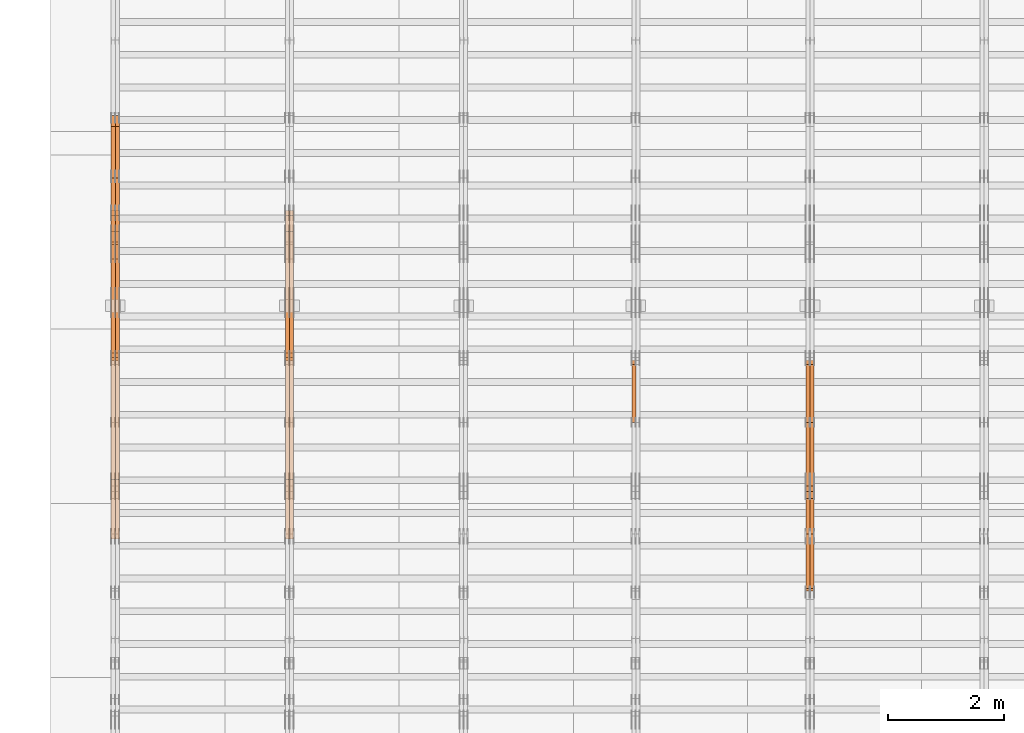
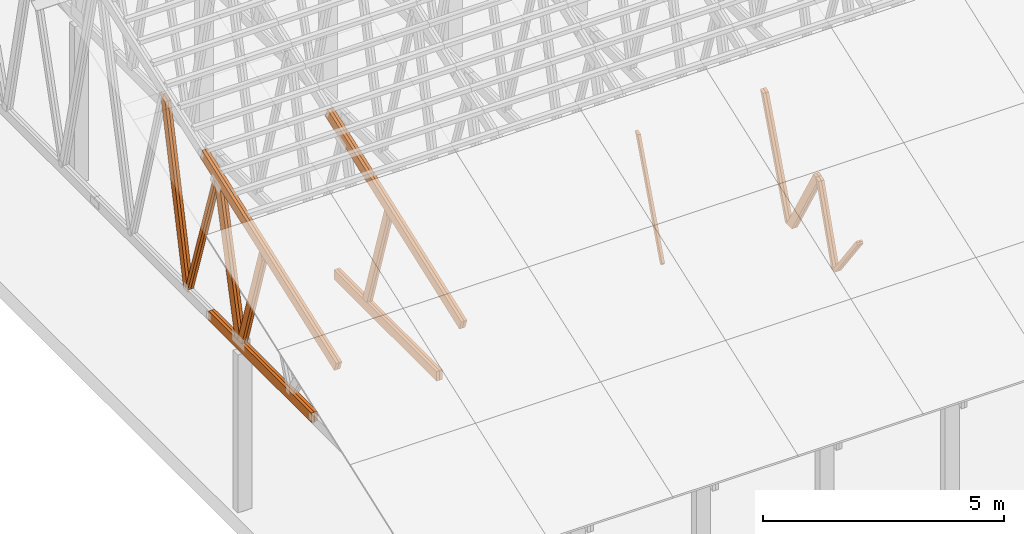
# One storey, part 15 of 189: 27 proxies.
"""IFC2X3 building model written with IfcOpenShell, lengths in millimetres."""

from ifc_helpers import new_model, entity, si_unit, converted_unit, derived_unit, direction, frame, origin, origin_2d_with_axis, place, context, subcontext, project, spatial, polyline, rectangle, outline, extrude, source, transform, mapped, material, type_object, type_shapes, element, save


model = new_model("IFC2X3")

# Units and contexts
model_context = context("Model", 3, precision=0.01, world=origin(), true_north=direction((6.12303176911189e-17, 1.0)))
body_context = subcontext(model_context, "Body", "Model", "MODEL_VIEW")
ifc_project = project(units=[si_unit("LENGTHUNIT", "METRE", prefix="MILLI"), si_unit("AREAUNIT", "SQUARE_METRE"), si_unit("VOLUMEUNIT", "CUBIC_METRE"), converted_unit("PLANEANGLEUNIT", "DEGREE", entity("IfcRatioMeasure", 0.0174532925199433), si_unit("PLANEANGLEUNIT", "RADIAN"), dimensions=[0, 0, 0, 0, 0, 0, 0]), si_unit("MASSUNIT", "GRAM", prefix="KILO"), derived_unit("MASSDENSITYUNIT", [(si_unit("MASSUNIT", "GRAM", prefix="KILO"), 1), (si_unit("LENGTHUNIT", "METRE"), -3)]), si_unit("TIMEUNIT", "SECOND"), si_unit("FREQUENCYUNIT", "HERTZ"), si_unit("THERMODYNAMICTEMPERATUREUNIT", "DEGREE_CELSIUS"), derived_unit("THERMALTRANSMITTANCEUNIT", [(si_unit("MASSUNIT", "GRAM", prefix="KILO"), 1), (si_unit("THERMODYNAMICTEMPERATUREUNIT", "KELVIN"), -1), (si_unit("TIMEUNIT", "SECOND"), -3)]), derived_unit("VOLUMETRICFLOWRATEUNIT", [(si_unit("LENGTHUNIT", "METRE"), 3), (si_unit("TIMEUNIT", "SECOND"), -1)]), si_unit("ELECTRICCURRENTUNIT", "AMPERE"), si_unit("ELECTRICVOLTAGEUNIT", "VOLT"), si_unit("POWERUNIT", "WATT"), si_unit("FORCEUNIT", "NEWTON"), si_unit("ILLUMINANCEUNIT", "LUX"), si_unit("LUMINOUSFLUXUNIT", "LUMEN"), si_unit("LUMINOUSINTENSITYUNIT", "CANDELA"), derived_unit("USERDEFINED", [(si_unit("MASSUNIT", "GRAM", prefix="KILO"), -1), (si_unit("LENGTHUNIT", "METRE"), -2), (si_unit("TIMEUNIT", "SECOND"), 3), (si_unit("LUMINOUSFLUXUNIT", "LUMEN"), 1)]), derived_unit("LINEARVELOCITYUNIT", [(si_unit("LENGTHUNIT", "METRE"), 1), (si_unit("TIMEUNIT", "SECOND"), -1)]), si_unit("PRESSUREUNIT", "PASCAL"), derived_unit("USERDEFINED", [(si_unit("LENGTHUNIT", "METRE"), -2), (si_unit("MASSUNIT", "GRAM", prefix="KILO"), 1), (si_unit("TIMEUNIT", "SECOND"), -2)])], contexts=[model_context])

# Site, building, storey
site_placement = place(None, origin())
site = spatial("IfcSite", under=ifc_project, at=site_placement, CompositionType="ELEMENT")
building_placement = place(site_placement, origin())
building = spatial("IfcBuilding", under=site, at=building_placement, CompositionType="ELEMENT")
storey_placement = place(building_placement, origin())
storey = spatial("IfcBuildingStorey", under=building, at=storey_placement, Name="Default", CompositionType="ELEMENT", Elevation=0.0)

# Proxies
ifc_material_1 = material(Name="IfcSurfaceStyle #67050")
building_element_proxy_type_1 = type_object("IfcBuildingElementProxyType", Name="T1-W8 67048", PredefinedType="NOTDEFINED", material=ifc_material_1)
shared_shape_1 = source(origin(), body_context, "Body", "SweptSolid", [
    extrude(outline(polyline([(-1781.70529904483, -47.500320228718), (1161.65050357787, -47.5003202287179), (1179.56135870849, 0.000731866266039397), (1140.6022069428, 47.4998218997103), (-1700.10877018433, 47.5000866914596), (-1781.70529904483, -47.500320228718)])), frame((1179.56135870869, 47.5007236522113, 0.0), z_axis=(0.0, 0.0, 1.0), x_axis=(-1.0, 3.74658825645258e-07, 0.0)), (0.0, 0.0, 1.0), 69.9999999999998),
])
type_shapes(building_element_proxy_type_1, [shared_shape_1])
proxy_1_placement = place(building_placement, frame((12300.0, 6723.5697965901, 261.758864533503), z_axis=(-1.0, 0.0, 0.0), x_axis=(0.0, 0.352814979177603, 0.93569310698963)))
element("IfcBuildingElementProxy", 1, at=proxy_1_placement, inside=storey, type_object=building_element_proxy_type_1, material=ifc_material_1, Name="T1-W8", context=body_context, shape_type="MappedRepresentation", body=[
    mapped(shared_shape_1, transform((0.0, 0.0, 0.0), scale=1.0)),
])
ifc_material_2 = material(Name="IfcSurfaceStyle #66984")
building_element_proxy_type_2 = type_object("IfcBuildingElementProxyType", Name="T1-W8 66982", PredefinedType="NOTDEFINED", material=ifc_material_2)
shared_shape_2 = source(origin(), body_context, "Body", "SweptSolid", [
    extrude(outline(polyline([(-1781.70529904483, -47.500320228718), (1161.65050357787, -47.5003202287179), (1179.56135870849, 0.000731866266039397), (1140.6022069428, 47.4998218997103), (-1700.10877018433, 47.5000866914596), (-1781.70529904483, -47.500320228718)])), frame((1179.56135870869, 47.5007236522113, 0.0), z_axis=(0.0, 0.0, 1.0), x_axis=(-1.0, 3.74658825645258e-07, 0.0)), (0.0, 0.0, 1.0), 69.9999999999998),
])
type_shapes(building_element_proxy_type_2, [shared_shape_2])
proxy_2_placement = place(building_placement, frame((12230.0, 6723.5697965901, 261.758864533503), z_axis=(-1.0, 0.0, 0.0), x_axis=(0.0, 0.352814979177603, 0.93569310698963)))
element("IfcBuildingElementProxy", 2, at=proxy_2_placement, inside=storey, type_object=building_element_proxy_type_2, material=ifc_material_2, Name="T1-W8", context=body_context, shape_type="MappedRepresentation", body=[
    mapped(shared_shape_2, transform((0.0, 0.0, 0.0), scale=1.0)),
])
ifc_material_3 = material(Name="IfcSurfaceStyle #66786")
building_element_proxy_type_3 = type_object("IfcBuildingElementProxyType", Name="T1-W2 66784", PredefinedType="NOTDEFINED", material=ifc_material_3)
shared_shape_3 = source(origin(), body_context, "Body", "SweptSolid", [
    extrude(outline(polyline([(-765.033104991319, -1130.91940266317), (-539.905732758898, -1130.91940266317), (493.678280567457, 660.584515081422), (452.144945212405, 783.697385511457), (359.115611970356, 817.556904733455), (-765.033104991319, -1130.91940266317)])), frame((904.774360566371, 97.5002668805543, 0.0), z_axis=(0.0, 0.0, 1.0), x_axis=(-0.499731715721184, 0.866180242387438, 0.0)), (0.0, 0.0, 1.0), 69.9999999999998),
])
type_shapes(building_element_proxy_type_3, [shared_shape_3])
proxy_3_placement = place(building_placement, frame((12300.0, 5635.28919163287, 2208.3400784451), z_axis=(-1.0, 0.0, 0.0), x_axis=(0.0, 0.5, -0.866025403784439)))
element("IfcBuildingElementProxy", 3, at=proxy_3_placement, inside=storey, type_object=building_element_proxy_type_3, material=ifc_material_3, Name="T1-W2", context=body_context, shape_type="MappedRepresentation", body=[
    mapped(shared_shape_3, transform((0.0, 0.0, 0.0), scale=1.0)),
])
ifc_material_4 = material(Name="IfcSurfaceStyle #66720")
building_element_proxy_type_4 = type_object("IfcBuildingElementProxyType", Name="T1-W2 66718", PredefinedType="NOTDEFINED", material=ifc_material_4)
shared_shape_4 = source(origin(), body_context, "Body", "SweptSolid", [
    extrude(outline(polyline([(-765.033104991319, -1130.91940266317), (-539.905732758898, -1130.91940266317), (493.678280567457, 660.584515081422), (452.144945212405, 783.697385511457), (359.115611970356, 817.556904733455), (-765.033104991319, -1130.91940266317)])), frame((904.774360566371, 97.5002668805543, 0.0), z_axis=(0.0, 0.0, 1.0), x_axis=(-0.499731715721184, 0.866180242387438, 0.0)), (0.0, 0.0, 1.0), 69.9999999999998),
])
type_shapes(building_element_proxy_type_4, [shared_shape_4])
proxy_4_placement = place(building_placement, frame((12230.0, 5635.28919163287, 2208.3400784451), z_axis=(-1.0, 0.0, 0.0), x_axis=(0.0, 0.5, -0.866025403784439)))
element("IfcBuildingElementProxy", 4, at=proxy_4_placement, inside=storey, type_object=building_element_proxy_type_4, material=ifc_material_4, Name="T1-W2", context=body_context, shape_type="MappedRepresentation", body=[
    mapped(shared_shape_4, transform((0.0, 0.0, 0.0), scale=1.0)),
])
ifc_material_5 = material(Name="IfcSurfaceStyle #66522")
building_element_proxy_type_5 = type_object("IfcBuildingElementProxyType", Name="T1-W9 66520", PredefinedType="NOTDEFINED", material=ifc_material_5)
shared_shape_5 = source(origin(), body_context, "Body", "SweptSolid", [
    extrude(outline(polyline([(-1227.3969292634, -47.5000382896404), (793.242467803064, -47.5000382896404), (809.267705296822, 1.0956605530188e-05), (776.329919980315, 47.5000328113376), (-1151.4431638168, 47.5000328113376), (-1227.3969292634, -47.5000382896404)])), frame((809.267705296822, 47.5000328113376, 0.0), z_axis=(0.0, 0.0, 1.0), x_axis=(-1.0, 0.0, 0.0)), (0.0, 0.0, 1.0), 69.9999999999999),
])
type_shapes(building_element_proxy_type_5, [shared_shape_5])
proxy_5_placement = place(building_placement, frame((12300.0, 4809.76380889125, 260.184242613649), z_axis=(-1.0, 0.0, 0.0), x_axis=(0.0, 0.31966811847134, 0.947529574226047)))
element("IfcBuildingElementProxy", 5, at=proxy_5_placement, inside=storey, type_object=building_element_proxy_type_5, material=ifc_material_5, Name="T1-W9", context=body_context, shape_type="MappedRepresentation", body=[
    mapped(shared_shape_5, transform((0.0, 0.0, 0.0), scale=1.0)),
])
ifc_material_6 = material(Name="IfcSurfaceStyle #66456")
building_element_proxy_type_6 = type_object("IfcBuildingElementProxyType", Name="T1-W9 66454", PredefinedType="NOTDEFINED", material=ifc_material_6)
shared_shape_6 = source(origin(), body_context, "Body", "SweptSolid", [
    extrude(outline(polyline([(-1227.3969292634, -47.5000382896404), (793.242467803064, -47.5000382896404), (809.267705296822, 1.0956605530188e-05), (776.329919980315, 47.5000328113376), (-1151.4431638168, 47.5000328113376), (-1227.3969292634, -47.5000382896404)])), frame((809.267705296822, 47.5000328113376, 0.0), z_axis=(0.0, 0.0, 1.0), x_axis=(-1.0, 0.0, 0.0)), (0.0, 0.0, 1.0), 69.9999999999999),
])
type_shapes(building_element_proxy_type_6, [shared_shape_6])
proxy_6_placement = place(building_placement, frame((12230.0, 4809.76380889125, 260.184242613649), z_axis=(-1.0, 0.0, 0.0), x_axis=(0.0, 0.31966811847134, 0.947529574226047)))
element("IfcBuildingElementProxy", 6, at=proxy_6_placement, inside=storey, type_object=building_element_proxy_type_6, material=ifc_material_6, Name="T1-W9", context=body_context, shape_type="MappedRepresentation", body=[
    mapped(shared_shape_6, transform((0.0, 0.0, 0.0), scale=1.0)),
])
ifc_material_7 = material(Name="IfcSurfaceStyle #66258")
building_element_proxy_type_7 = type_object("IfcBuildingElementProxyType", Name="T1-W10 66256", PredefinedType="NOTDEFINED", material=ifc_material_7)
shared_shape_7 = source(origin(), body_context, "Body", "SweptSolid", [
    extrude(outline(polyline([(-922.639472665691, -47.5001890573134), (629.920966338637, -47.5001890573134), (650.067737483374, 0.000694680531158376), (635.89112756682, 47.4998417170478), (-993.240358723139, 47.4998417170478), (-922.639472665691, -47.5001890573134)])), frame((650.068202545693, 47.4999816623145, 0.0), z_axis=(0.0, 0.0, 1.0), x_axis=(-1.0, 0.0, 0.0)), (0.0, 0.0, 1.0), 69.9999999999999),
])
type_shapes(building_element_proxy_type_7, [shared_shape_7])
proxy_7_placement = place(building_placement, frame((12300.0, 3874.56126239818, 1563.95828147518), z_axis=(-1.0, 0.0, 0.0), x_axis=(0.0, 0.596486092002, -0.802623412347398)))
element("IfcBuildingElementProxy", 7, at=proxy_7_placement, inside=storey, type_object=building_element_proxy_type_7, material=ifc_material_7, Name="T1-W10", context=body_context, shape_type="MappedRepresentation", body=[
    mapped(shared_shape_7, transform((0.0, 0.0, 0.0), scale=1.0)),
])
ifc_material_8 = material(Name="IfcSurfaceStyle #66192")
building_element_proxy_type_8 = type_object("IfcBuildingElementProxyType", Name="T1-W10 66190", PredefinedType="NOTDEFINED", material=ifc_material_8)
shared_shape_8 = source(origin(), body_context, "Body", "SweptSolid", [
    extrude(outline(polyline([(-922.639472665691, -47.5001890573134), (629.920966338637, -47.5001890573134), (650.067737483374, 0.000694680531158376), (635.89112756682, 47.4998417170478), (-993.240358723139, 47.4998417170478), (-922.639472665691, -47.5001890573134)])), frame((650.068202545693, 47.4999816623145, 0.0), z_axis=(0.0, 0.0, 1.0), x_axis=(-1.0, 0.0, 0.0)), (0.0, 0.0, 1.0), 69.9999999999999),
])
type_shapes(building_element_proxy_type_8, [shared_shape_8])
proxy_8_placement = place(building_placement, frame((12230.0, 3874.56126239818, 1563.95828147518), z_axis=(-1.0, 0.0, 0.0), x_axis=(0.0, 0.596486092002, -0.802623412347398)))
element("IfcBuildingElementProxy", 8, at=proxy_8_placement, inside=storey, type_object=building_element_proxy_type_8, material=ifc_material_8, Name="T1-W10", context=body_context, shape_type="MappedRepresentation", body=[
    mapped(shared_shape_8, transform((0.0, 0.0, 0.0), scale=1.0)),
])
ifc_material_9 = material(Name="IfcSurfaceStyle #51194")
building_element_proxy_type_9 = type_object("IfcBuildingElementProxyType", Name="T1-W8 51192", PredefinedType="NOTDEFINED", material=ifc_material_9)
shared_shape_9 = source(origin(), body_context, "Body", "SweptSolid", [
    extrude(outline(polyline([(-1781.70529904483, -47.500320228718), (1161.65050357787, -47.5003202287179), (1179.56135870849, 0.000731866266039397), (1140.6022069428, 47.4998218997103), (-1700.10877018433, 47.5000866914596), (-1781.70529904483, -47.500320228718)])), frame((1179.56135870869, 47.5007236522113, 0.0), z_axis=(0.0, 0.0, 1.0), x_axis=(-1.0, 3.74658825645258e-07, 0.0)), (0.0, 0.0, 1.0), 69.9999999999998),
])
type_shapes(building_element_proxy_type_9, [shared_shape_9])
proxy_9_placement = place(building_placement, frame((9230.0, 6723.5697965901, 261.758864533503), z_axis=(-1.0, 0.0, 0.0), x_axis=(0.0, 0.352814979177603, 0.93569310698963)))
element("IfcBuildingElementProxy", 9, at=proxy_9_placement, inside=storey, type_object=building_element_proxy_type_9, material=ifc_material_9, Name="T1-W8", context=body_context, shape_type="MappedRepresentation", body=[
    mapped(shared_shape_9, transform((0.0, 0.0, 0.0), scale=1.0)),
])
ifc_material_10 = material(Name="IfcSurfaceStyle #19944")
building_element_proxy_type_10 = type_object("IfcBuildingElementProxyType", Name="T1-W4 19942", PredefinedType="NOTDEFINED", material=ifc_material_10)
shared_shape_10 = source(origin(), body_context, "Body", "SweptSolid", [
    extrude(outline(polyline([(-1688.09292256655, -85.0003489723785), (1071.44998120742, -85.0003489723785), (1178.19407811536, -0.00016040063201781), (1181.35435681367, 85.0004291726946), (-1742.9054935699, 85.0004291726946), (-1688.09292256655, -85.0003489723785)])), frame((1181.35446122976, 85.0007670757732, 0.0), z_axis=(0.0, 0.0, 1.0), x_axis=(-1.0, 0.0, 0.0)), (0.0, 0.0, 1.0), 69.9999999999998),
])
type_shapes(building_element_proxy_type_10, [shared_shape_10])
proxy_10_placement = place(building_placement, frame((3335.0, 7937.17021143291, 3028.170124945), z_axis=(-1.0, 0.0, 0.0), x_axis=(0.0, 0.306868406216492, -0.951751953644514)))
element("IfcBuildingElementProxy", 10, at=proxy_10_placement, inside=storey, type_object=building_element_proxy_type_10, material=ifc_material_10, Name="T1-W4", context=body_context, shape_type="MappedRepresentation", body=[
    mapped(shared_shape_10, transform((0.0, 0.0, 0.0), scale=1.0)),
])
ifc_material_11 = material(Name="IfcSurfaceStyle #19878")
building_element_proxy_type_11 = type_object("IfcBuildingElementProxyType", Name="T1-W4 19876", PredefinedType="NOTDEFINED", material=ifc_material_11)
shared_shape_11 = source(origin(), body_context, "Body", "SweptSolid", [
    extrude(outline(polyline([(-1688.09292256655, -85.0003489723785), (1071.44998120742, -85.0003489723785), (1178.19407811536, -0.00016040063201781), (1181.35435681367, 85.0004291726946), (-1742.9054935699, 85.0004291726946), (-1688.09292256655, -85.0003489723785)])), frame((1181.35446122976, 85.0007670757732, 0.0), z_axis=(0.0, 0.0, 1.0), x_axis=(-1.0, 0.0, 0.0)), (0.0, 0.0, 1.0), 69.9999999999998),
])
type_shapes(building_element_proxy_type_11, [shared_shape_11])
proxy_11_placement = place(building_placement, frame((3265.0, 7937.17021143291, 3028.170124945), z_axis=(-1.0, 0.0, 0.0), x_axis=(0.0, 0.306868406216492, -0.951751953644514)))
element("IfcBuildingElementProxy", 11, at=proxy_11_placement, inside=storey, type_object=building_element_proxy_type_11, material=ifc_material_11, Name="T1-W4", context=body_context, shape_type="MappedRepresentation", body=[
    mapped(shared_shape_11, transform((0.0, 0.0, 0.0), scale=1.0)),
])
ifc_material_12 = material(Name="IfcSurfaceStyle #16866")
building_element_proxy_type_12 = type_object("IfcBuildingElementProxyType", Name="T1-B6 16864", PredefinedType="NOTDEFINED", material=ifc_material_12)
shared_shape_12 = source(origin(), body_context, "Body", "SweptSolid", [
    extrude(rectangle(XDim=4266.763671875, YDim=245.000000000001, at=origin_2d_with_axis()), frame((2133.3818359375, 122.500000000001, 0.0), z_axis=(0.0, 0.0, 1.0), x_axis=(-1.0, 0.0, 0.0)), (0.0, 0.0, 1.0), 69.9999999999997),
])
type_shapes(building_element_proxy_type_12, [shared_shape_12])
proxy_12_placement = place(building_placement, frame((3335.0, 5762.466796875, 245.0), z_axis=(-1.0, 0.0, 0.0), x_axis=(0.0, 1.0, 0.0)))
element("IfcBuildingElementProxy", 12, at=proxy_12_placement, inside=storey, type_object=building_element_proxy_type_12, material=ifc_material_12, Name="T1-B6", context=body_context, shape_type="MappedRepresentation", body=[
    mapped(shared_shape_12, transform((0.0, 0.0, 0.0), scale=1.0)),
])
ifc_material_13 = material(Name="IfcSurfaceStyle #16809")
building_element_proxy_type_13 = type_object("IfcBuildingElementProxyType", Name="T1-B6 16807", PredefinedType="NOTDEFINED", material=ifc_material_13)
shared_shape_13 = source(origin(), body_context, "Body", "SweptSolid", [
    extrude(rectangle(XDim=4266.763671875, YDim=245.000000000001, at=origin_2d_with_axis()), frame((2133.3818359375, 122.500000000001, 0.0), z_axis=(0.0, 0.0, 1.0), x_axis=(-1.0, 0.0, 0.0)), (0.0, 0.0, 1.0), 69.9999999999997),
])
type_shapes(building_element_proxy_type_13, [shared_shape_13])
proxy_13_placement = place(building_placement, frame((3265.0, 5762.466796875, 245.0), z_axis=(-1.0, 0.0, 0.0), x_axis=(0.0, 1.0, 0.0)))
element("IfcBuildingElementProxy", 13, at=proxy_13_placement, inside=storey, type_object=building_element_proxy_type_13, material=ifc_material_13, Name="T1-B6", context=body_context, shape_type="MappedRepresentation", body=[
    mapped(shared_shape_13, transform((0.0, 0.0, 0.0), scale=1.0)),
])
ifc_material_14 = material(Name="IfcSurfaceStyle #16506")
building_element_proxy_type_14 = type_object("IfcBuildingElementProxyType", Name="T1-T1 16504", PredefinedType="NOTDEFINED", material=ifc_material_14)
shared_shape_14 = source(origin(), body_context, "Body", "SweptSolid", [
    extrude(outline(polyline([(-2964.99981923522, -122.500027388895), (2964.99982426074, -122.500027388895), (2964.99984011048, 122.500027388895), (-2964.99984513599, 122.500027388895), (-2964.99981923522, -122.500027388895)])), frame((2965.00021857317, 122.500056320695, 0.0), z_axis=(0.0, 0.0, 1.0), x_axis=(-1.0, 0.0, 0.0)), (0.0, 0.0, 1.0), 69.9999999999996),
])
type_shapes(building_element_proxy_type_14, [shared_shape_14])
proxy_14_placement = place(building_placement, frame((3335.0, 10391.0374749089, 3921.30478975487), z_axis=(-1.0, 0.0, 0.0), x_axis=(0.0, -0.939692620785908, -0.342020143325669)))
element("IfcBuildingElementProxy", 14, at=proxy_14_placement, inside=storey, type_object=building_element_proxy_type_14, material=ifc_material_14, Name="T1-T1", context=body_context, shape_type="MappedRepresentation", body=[
    mapped(shared_shape_14, transform((0.0, 0.0, 0.0), scale=1.0)),
])
ifc_material_15 = material(Name="IfcSurfaceStyle #16449")
building_element_proxy_type_15 = type_object("IfcBuildingElementProxyType", Name="T1-T1 16447", PredefinedType="NOTDEFINED", material=ifc_material_15)
shared_shape_15 = source(origin(), body_context, "Body", "SweptSolid", [
    extrude(outline(polyline([(-2964.99981923522, -122.500027388895), (2964.99982426074, -122.500027388895), (2964.99984011048, 122.500027388895), (-2964.99984513599, 122.500027388895), (-2964.99981923522, -122.500027388895)])), frame((2965.00021857317, 122.500056320695, 0.0), z_axis=(0.0, 0.0, 1.0), x_axis=(-1.0, 0.0, 0.0)), (0.0, 0.0, 1.0), 69.9999999999996),
])
type_shapes(building_element_proxy_type_15, [shared_shape_15])
proxy_15_placement = place(building_placement, frame((3265.0, 10391.0374749089, 3921.30478975487), z_axis=(-1.0, 0.0, 0.0), x_axis=(0.0, -0.939692620785908, -0.342020143325669)))
element("IfcBuildingElementProxy", 15, at=proxy_15_placement, inside=storey, type_object=building_element_proxy_type_15, material=ifc_material_15, Name="T1-T1", context=body_context, shape_type="MappedRepresentation", body=[
    mapped(shared_shape_15, transform((0.0, 0.0, 0.0), scale=1.0)),
])
ifc_material_16 = material(Name="IfcSurfaceStyle #4943")
building_element_proxy_type_16 = type_object("IfcBuildingElementProxyType", Name="T1-W3 4941", PredefinedType="NOTDEFINED", material=ifc_material_16)
shared_shape_16 = source(origin(), body_context, "Body", "SweptSolid", [
    extrude(outline(polyline([(-2625.55080717397, -84.9998286237256), (1749.48871563991, -84.9998286237256), (1768.20584427244, 0.000602085469291858), (1625.445846867, 85.0000405971208), (-2517.58959960538, 84.9990145648612), (-2625.55080717397, -84.9998286237256)])), frame((1768.20584427244, 85.0000405971208, 0.0), z_axis=(0.0, 0.0, 1.0), x_axis=(-1.0, 0.0, 0.0)), (0.0, 0.0, 1.0), 69.9999999999997),
])
type_shapes(building_element_proxy_type_16, [shared_shape_16])
proxy_16_placement = place(building_placement, frame((335.0, 10918.6728403286, 263.278932236374), z_axis=(-1.0, 0.0, 0.0), x_axis=(0.0, 0.215047682154604, 0.976603550269982)))
element("IfcBuildingElementProxy", 16, at=proxy_16_placement, inside=storey, type_object=building_element_proxy_type_16, material=ifc_material_16, Name="T1-W3", context=body_context, shape_type="MappedRepresentation", body=[
    mapped(shared_shape_16, transform((0.0, 0.0, 0.0), scale=1.0)),
])
ifc_material_17 = material(Name="IfcSurfaceStyle #4877")
building_element_proxy_type_17 = type_object("IfcBuildingElementProxyType", Name="T1-W3 4875", PredefinedType="NOTDEFINED", material=ifc_material_17)
shared_shape_17 = source(origin(), body_context, "Body", "SweptSolid", [
    extrude(outline(polyline([(-2625.55080717397, -84.9998286237256), (1749.48871563991, -84.9998286237256), (1768.20584427244, 0.000602085469291858), (1625.445846867, 85.0000405971208), (-2517.58959960538, 84.9990145648612), (-2625.55080717397, -84.9998286237256)])), frame((1768.20584427244, 85.0000405971208, 0.0), z_axis=(0.0, 0.0, 1.0), x_axis=(-1.0, 0.0, 0.0)), (0.0, 0.0, 1.0), 69.9999999999997),
])
type_shapes(building_element_proxy_type_17, [shared_shape_17])
proxy_17_placement = place(building_placement, frame((265.0, 10918.6728403286, 263.278932236374), z_axis=(-1.0, 0.0, 0.0), x_axis=(0.0, 0.215047682154604, 0.976603550269982)))
element("IfcBuildingElementProxy", 17, at=proxy_17_placement, inside=storey, type_object=building_element_proxy_type_17, material=ifc_material_17, Name="T1-W3", context=body_context, shape_type="MappedRepresentation", body=[
    mapped(shared_shape_17, transform((0.0, 0.0, 0.0), scale=1.0)),
])
ifc_material_18 = material(Name="IfcSurfaceStyle #4679")
building_element_proxy_type_18 = type_object("IfcBuildingElementProxyType", Name="T1-W7 4677", PredefinedType="NOTDEFINED", material=ifc_material_18)
shared_shape_18 = source(origin(), body_context, "Body", "SweptSolid", [
    extrude(outline(polyline([(-2158.15323194511, -47.5001976605119), (1398.58481981178, -47.5001976605119), (1473.93376219819, -0.000131511554346808), (1475.30069254941, 47.5002634162891), (-2189.66604261427, 47.5002634162891), (-2158.15323194511, -47.5001976605119)])), frame((1475.30069254941, 47.5002634162891, 0.0), z_axis=(0.0, 0.0, 1.0), x_axis=(-1.0, 0.0, 0.0)), (0.0, 0.0, 1.0), 69.9999999999998),
])
type_shapes(building_element_proxy_type_18, [shared_shape_18])
proxy_18_placement = place(building_placement, frame((335.0, 9847.787109375, 3723.57788085937), z_axis=(-1.0, 0.0, 0.0), x_axis=(0.0, 0.314845237923105, -0.949143021971475)))
element("IfcBuildingElementProxy", 18, at=proxy_18_placement, inside=storey, type_object=building_element_proxy_type_18, material=ifc_material_18, Name="T1-W7", context=body_context, shape_type="MappedRepresentation", body=[
    mapped(shared_shape_18, transform((0.0, 0.0, 0.0), scale=1.0)),
])
ifc_material_19 = material(Name="IfcSurfaceStyle #4613")
building_element_proxy_type_19 = type_object("IfcBuildingElementProxyType", Name="T1-W7 4611", PredefinedType="NOTDEFINED", material=ifc_material_19)
shared_shape_19 = source(origin(), body_context, "Body", "SweptSolid", [
    extrude(outline(polyline([(-2158.15323194511, -47.5001976605119), (1398.58481981178, -47.5001976605119), (1473.93376219819, -0.000131511554346808), (1475.30069254941, 47.5002634162891), (-2189.66604261427, 47.5002634162891), (-2158.15323194511, -47.5001976605119)])), frame((1475.30069254941, 47.5002634162891, 0.0), z_axis=(0.0, 0.0, 1.0), x_axis=(-1.0, 0.0, 0.0)), (0.0, 0.0, 1.0), 69.9999999999998),
])
type_shapes(building_element_proxy_type_19, [shared_shape_19])
proxy_19_placement = place(building_placement, frame((265.0, 9847.787109375, 3723.57788085937), z_axis=(-1.0, 0.0, 0.0), x_axis=(0.0, 0.314845237923105, -0.949143021971475)))
element("IfcBuildingElementProxy", 19, at=proxy_19_placement, inside=storey, type_object=building_element_proxy_type_19, material=ifc_material_19, Name="T1-W7", context=body_context, shape_type="MappedRepresentation", body=[
    mapped(shared_shape_19, transform((0.0, 0.0, 0.0), scale=1.0)),
])
ifc_material_20 = material(Name="IfcSurfaceStyle #4415")
building_element_proxy_type_20 = type_object("IfcBuildingElementProxyType", Name="T1-W1 4413", PredefinedType="NOTDEFINED", material=ifc_material_20)
shared_shape_20 = source(origin(), body_context, "Body", "SweptSolid", [
    extrude(outline(polyline([(-2144.69382208629, -109.99948311278), (1421.70798092021, -109.99948311278), (1448.88116133745, -0.000392715405943322), (1271.09900468242, 109.999679470483), (-1996.99432485378, 109.999679470483), (-2144.69382208629, -109.99948311278)])), frame((1448.88130194731, 110.000176487146, 0.0), z_axis=(0.0, 0.0, 1.0), x_axis=(-1.0, 0.0, 0.0)), (0.0, 0.0, 1.0), 69.9999999999998),
])
type_shapes(building_element_proxy_type_20, [shared_shape_20])
proxy_20_placement = place(building_placement, frame((335.0, 8727.74270166583, 271.380182391418), z_axis=(-1.0, 0.0, 0.0), x_axis=(0.0, 0.239819839925978, 0.970817410421691)))
element("IfcBuildingElementProxy", 20, at=proxy_20_placement, inside=storey, type_object=building_element_proxy_type_20, material=ifc_material_20, Name="T1-W1", context=body_context, shape_type="MappedRepresentation", body=[
    mapped(shared_shape_20, transform((0.0, 0.0, 0.0), scale=1.0)),
])
ifc_material_21 = material(Name="IfcSurfaceStyle #4349")
building_element_proxy_type_21 = type_object("IfcBuildingElementProxyType", Name="T1-W1 4347", PredefinedType="NOTDEFINED", material=ifc_material_21)
shared_shape_21 = source(origin(), body_context, "Body", "SweptSolid", [
    extrude(outline(polyline([(-2144.69382208629, -109.99948311278), (1421.70798092021, -109.99948311278), (1448.88116133745, -0.000392715405943322), (1271.09900468242, 109.999679470483), (-1996.99432485378, 109.999679470483), (-2144.69382208629, -109.99948311278)])), frame((1448.88130194731, 110.000176487146, 0.0), z_axis=(0.0, 0.0, 1.0), x_axis=(-1.0, 0.0, 0.0)), (0.0, 0.0, 1.0), 69.9999999999998),
])
type_shapes(building_element_proxy_type_21, [shared_shape_21])
proxy_21_placement = place(building_placement, frame((265.0, 8727.74270166583, 271.380182391418), z_axis=(-1.0, 0.0, 0.0), x_axis=(0.0, 0.239819839925978, 0.970817410421691)))
element("IfcBuildingElementProxy", 21, at=proxy_21_placement, inside=storey, type_object=building_element_proxy_type_21, material=ifc_material_21, Name="T1-W1", context=body_context, shape_type="MappedRepresentation", body=[
    mapped(shared_shape_21, transform((0.0, 0.0, 0.0), scale=1.0)),
])
ifc_material_22 = material(Name="IfcSurfaceStyle #4151")
building_element_proxy_type_22 = type_object("IfcBuildingElementProxyType", Name="T1-W4 4149", PredefinedType="NOTDEFINED", material=ifc_material_22)
shared_shape_22 = source(origin(), body_context, "Body", "SweptSolid", [
    extrude(outline(polyline([(-1688.09292256655, -85.0003489723785), (1071.44998120742, -85.0003489723785), (1178.19407811536, -0.00016040063201781), (1181.35435681367, 85.0004291726946), (-1742.9054935699, 85.0004291726946), (-1688.09292256655, -85.0003489723785)])), frame((1181.35446122976, 85.0007670757732, 0.0), z_axis=(0.0, 0.0, 1.0), x_axis=(-1.0, 0.0, 0.0)), (0.0, 0.0, 1.0), 69.9999999999998),
])
type_shapes(building_element_proxy_type_22, [shared_shape_22])
proxy_22_placement = place(building_placement, frame((335.0, 7937.17021143291, 3028.170124945), z_axis=(-1.0, 0.0, 0.0), x_axis=(0.0, 0.306868406216492, -0.951751953644514)))
element("IfcBuildingElementProxy", 22, at=proxy_22_placement, inside=storey, type_object=building_element_proxy_type_22, material=ifc_material_22, Name="T1-W4", context=body_context, shape_type="MappedRepresentation", body=[
    mapped(shared_shape_22, transform((0.0, 0.0, 0.0), scale=1.0)),
])
ifc_material_23 = material(Name="IfcSurfaceStyle #4085")
building_element_proxy_type_23 = type_object("IfcBuildingElementProxyType", Name="T1-W4 4083", PredefinedType="NOTDEFINED", material=ifc_material_23)
shared_shape_23 = source(origin(), body_context, "Body", "SweptSolid", [
    extrude(outline(polyline([(-1688.09292256655, -85.0003489723785), (1071.44998120742, -85.0003489723785), (1178.19407811536, -0.00016040063201781), (1181.35435681367, 85.0004291726946), (-1742.9054935699, 85.0004291726946), (-1688.09292256655, -85.0003489723785)])), frame((1181.35446122976, 85.0007670757732, 0.0), z_axis=(0.0, 0.0, 1.0), x_axis=(-1.0, 0.0, 0.0)), (0.0, 0.0, 1.0), 69.9999999999998),
])
type_shapes(building_element_proxy_type_23, [shared_shape_23])
proxy_23_placement = place(building_placement, frame((265.0, 7937.17021143291, 3028.170124945), z_axis=(-1.0, 0.0, 0.0), x_axis=(0.0, 0.306868406216492, -0.951751953644514)))
element("IfcBuildingElementProxy", 23, at=proxy_23_placement, inside=storey, type_object=building_element_proxy_type_23, material=ifc_material_23, Name="T1-W4", context=body_context, shape_type="MappedRepresentation", body=[
    mapped(shared_shape_23, transform((0.0, 0.0, 0.0), scale=1.0)),
])
ifc_material_24 = material(Name="IfcSurfaceStyle #1073")
building_element_proxy_type_24 = type_object("IfcBuildingElementProxyType", Name="T1-B6 1071", PredefinedType="NOTDEFINED", material=ifc_material_24)
shared_shape_24 = source(origin(), body_context, "Body", "SweptSolid", [
    extrude(rectangle(XDim=4266.763671875, YDim=245.000000000001, at=origin_2d_with_axis()), frame((2133.3818359375, 122.500000000001, 0.0), z_axis=(0.0, 0.0, 1.0), x_axis=(-1.0, 0.0, 0.0)), (0.0, 0.0, 1.0), 69.9999999999997),
])
type_shapes(building_element_proxy_type_24, [shared_shape_24])
proxy_24_placement = place(building_placement, frame((335.0, 5762.466796875, 245.0), z_axis=(-1.0, 0.0, 0.0), x_axis=(0.0, 1.0, 0.0)))
element("IfcBuildingElementProxy", 24, at=proxy_24_placement, inside=storey, type_object=building_element_proxy_type_24, material=ifc_material_24, Name="T1-B6", context=body_context, shape_type="MappedRepresentation", body=[
    mapped(shared_shape_24, transform((0.0, 0.0, 0.0), scale=1.0)),
])
ifc_material_25 = material(Name="IfcSurfaceStyle #1016")
building_element_proxy_type_25 = type_object("IfcBuildingElementProxyType", Name="T1-B6 1014", PredefinedType="NOTDEFINED", material=ifc_material_25)
shared_shape_25 = source(origin(), body_context, "Body", "SweptSolid", [
    extrude(rectangle(XDim=4266.763671875, YDim=245.000000000001, at=origin_2d_with_axis()), frame((2133.3818359375, 122.500000000001, 0.0), z_axis=(0.0, 0.0, 1.0), x_axis=(-1.0, 0.0, 0.0)), (0.0, 0.0, 1.0), 69.9999999999997),
])
type_shapes(building_element_proxy_type_25, [shared_shape_25])
proxy_25_placement = place(building_placement, frame((265.0, 5762.466796875, 245.0), z_axis=(-1.0, 0.0, 0.0), x_axis=(0.0, 1.0, 0.0)))
element("IfcBuildingElementProxy", 25, at=proxy_25_placement, inside=storey, type_object=building_element_proxy_type_25, material=ifc_material_25, Name="T1-B6", context=body_context, shape_type="MappedRepresentation", body=[
    mapped(shared_shape_25, transform((0.0, 0.0, 0.0), scale=1.0)),
])
ifc_material_26 = material(Name="IfcSurfaceStyle #713")
building_element_proxy_type_26 = type_object("IfcBuildingElementProxyType", Name="T1-T1 711", PredefinedType="NOTDEFINED", material=ifc_material_26)
shared_shape_26 = source(origin(), body_context, "Body", "SweptSolid", [
    extrude(outline(polyline([(-2964.99981923522, -122.500027388895), (2964.99982426074, -122.500027388895), (2964.99984011048, 122.500027388895), (-2964.99984513599, 122.500027388895), (-2964.99981923522, -122.500027388895)])), frame((2965.00021857317, 122.500056320695, 0.0), z_axis=(0.0, 0.0, 1.0), x_axis=(-1.0, 0.0, 0.0)), (0.0, 0.0, 1.0), 69.9999999999996),
])
type_shapes(building_element_proxy_type_26, [shared_shape_26])
proxy_26_placement = place(building_placement, frame((335.0, 10391.0374749089, 3921.30478975487), z_axis=(-1.0, 0.0, 0.0), x_axis=(0.0, -0.939692620785908, -0.342020143325669)))
element("IfcBuildingElementProxy", 26, at=proxy_26_placement, inside=storey, type_object=building_element_proxy_type_26, material=ifc_material_26, Name="T1-T1", context=body_context, shape_type="MappedRepresentation", body=[
    mapped(shared_shape_26, transform((0.0, 0.0, 0.0), scale=1.0)),
])
ifc_material_27 = material(Name="IfcSurfaceStyle #656")
building_element_proxy_type_27 = type_object("IfcBuildingElementProxyType", Name="T1-T1 654", PredefinedType="NOTDEFINED", material=ifc_material_27)
shared_shape_27 = source(origin(), body_context, "Body", "SweptSolid", [
    extrude(outline(polyline([(-2964.99981923522, -122.500027388895), (2964.99982426074, -122.500027388895), (2964.99984011048, 122.500027388895), (-2964.99984513599, 122.500027388895), (-2964.99981923522, -122.500027388895)])), frame((2965.00021857317, 122.500056320695, 0.0), z_axis=(0.0, 0.0, 1.0), x_axis=(-1.0, 0.0, 0.0)), (0.0, 0.0, 1.0), 69.9999999999996),
])
type_shapes(building_element_proxy_type_27, [shared_shape_27])
proxy_27_placement = place(building_placement, frame((265.0, 10391.0374749089, 3921.30478975487), z_axis=(-1.0, 0.0, 0.0), x_axis=(0.0, -0.939692620785908, -0.342020143325669)))
element("IfcBuildingElementProxy", 27, at=proxy_27_placement, inside=storey, type_object=building_element_proxy_type_27, material=ifc_material_27, Name="T1-T1", context=body_context, shape_type="MappedRepresentation", body=[
    mapped(shared_shape_27, transform((0.0, 0.0, 0.0), scale=1.0)),
])

save(model, "model.ifc")
